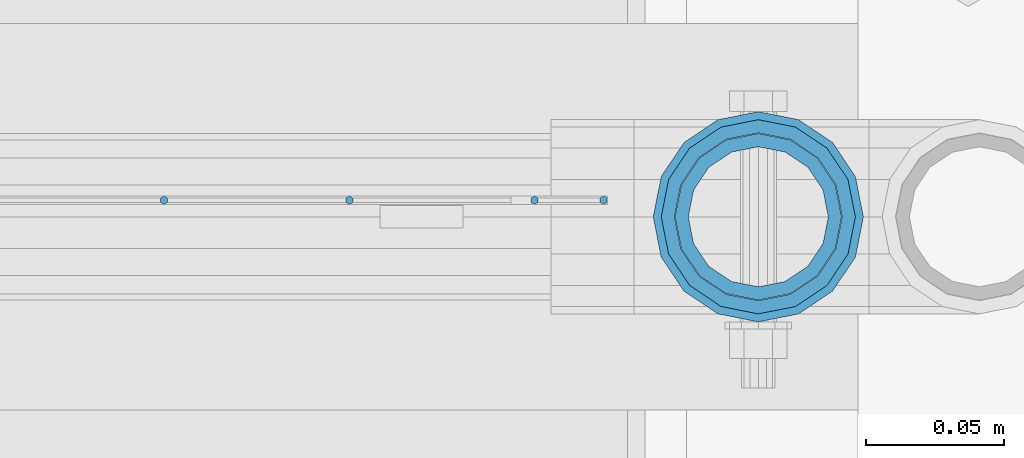
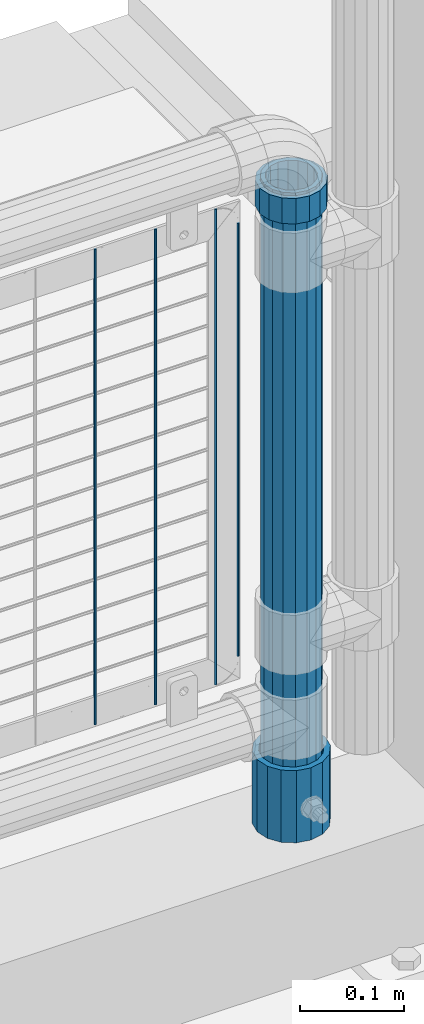
# One storey, part 88 of 208: 7 columns.
"""IFC2X3 building model written with IfcOpenShell, lengths in millimetres."""

import ifcopenshell
import ifcopenshell.guid

model = None  # the IFC model being written
_history = None  # IfcOwnerHistory: only IFC2X3 demands one
_inside = {}  # id of a spatial element -> (the spatial element, [elements in it])
_under = {}  # id of a project, library or spatial element -> (it, [spatial elements below it])
_declared = {}  # id of a project -> (the project, [libraries it declares])
_typed = {}  # id of a type object -> (the type object, [elements of that type])
_made_of = {}  # id of a material, layer set ... -> (it, [elements and type objects made of it])


def new_model(schema):
    """Start an empty IFC model of exactly this schema.

    Asked for "IFC4X3", IfcOpenShell would pick the latest addendum, in which some entities
    have other attributes; the version numbers below select the first issue.
    IFC2X3 requires an IfcOwnerHistory on every rooted entity: one is made here for all.
    """
    global model, _history
    if schema == "IFC4X3":
        model = ifcopenshell.file(schema_version=(4, 3, 0, 0))
    else:
        model = ifcopenshell.file(schema=schema)
    _inside.clear()
    _under.clear()
    _declared.clear()
    _typed.clear()
    _made_of.clear()
    _history = None
    if model.schema == "IFC2X3":
        org = make("IfcOrganization", Name="unknown")
        user = make(
            "IfcPersonAndOrganization",
            ThePerson=make("IfcPerson", FamilyName="unknown"),
            TheOrganization=org,
        )
        app = make(
            "IfcApplication",
            ApplicationDeveloper=org,
            Version="unknown",
            ApplicationFullName="unknown",
            ApplicationIdentifier="unknown",
        )
        _history = make(
            "IfcOwnerHistory",
            OwningUser=user,
            OwningApplication=app,
            ChangeAction="ADDED",
            CreationDate=0,
        )
    return model


def make(cls, **values):
    """One entity of the class cls with the attributes given. An attribute that is None is left unset."""
    return model.create_entity(
        cls, **{name: value for name, value in values.items() if value is not None}
    )


def rooted(cls, **values):
    """An entity with a GlobalId (a new one), such as an element, a storey or a relation."""
    return make(cls, GlobalId=ifcopenshell.guid.new(), OwnerHistory=_history, **values)


def si_unit(unit_type, name, prefix=None):
    """IfcSIUnit, for example si_unit("LENGTHUNIT", "METRE", prefix="MILLI")."""
    return make("IfcSIUnit", UnitType=unit_type, Prefix=prefix, Name=name)


def assignment(units):
    """IfcUnitAssignment: the units of a project."""
    return None if units is None else make("IfcUnitAssignment", Units=units)


def point(xyz):
    """IfcCartesianPoint."""
    return None if xyz is None else make("IfcCartesianPoint", Coordinates=xyz)


def direction(xyz):
    """IfcDirection."""
    return None if xyz is None else make("IfcDirection", DirectionRatios=xyz)


def frame(location, z_axis=None, x_axis=None):
    """IfcAxis2Placement3D, a coordinate frame: its origin and axes. An axis left out is left unset."""
    return make(
        "IfcAxis2Placement3D",
        Location=point(location),
        Axis=direction(z_axis),
        RefDirection=direction(x_axis),
    )


def origin_with_axes():
    """The frame at (0, 0, 0) with the z axis (0, 0, 1) and the x axis (1, 0, 0) written out."""
    return frame((0.0, 0.0, 0.0), z_axis=(0.0, 0.0, 1.0), x_axis=(1.0, 0.0, 0.0))


def place(relative_to, where):
    """IfcLocalPlacement: puts the frame where relative to a parent placement (None: the world)."""
    return make(
        "IfcLocalPlacement", PlacementRelTo=relative_to, RelativePlacement=where
    )


def context(
    kind, dimensions, precision=None, world=None, true_north=None, identifier=None
):
    """IfcGeometricRepresentationContext, for example the 3D "Model" context."""
    return make(
        "IfcGeometricRepresentationContext",
        ContextIdentifier=identifier,
        ContextType=kind,
        CoordinateSpaceDimension=dimensions,
        Precision=precision,
        WorldCoordinateSystem=world,
        TrueNorth=true_north,
    )


def subcontext(parent, identifier, kind, view, scale=None):
    """IfcGeometricRepresentationSubContext, for example "Body" below "Model"."""
    return make(
        "IfcGeometricRepresentationSubContext",
        ContextIdentifier=identifier,
        ContextType=kind,
        ParentContext=parent,
        TargetScale=scale,
        TargetView=view,
    )


def project(units=None, contexts=None):
    """IfcProject with its units and contexts."""
    return rooted(
        "IfcProject",
        Name="project",
        RepresentationContexts=contexts,
        UnitsInContext=assignment(units),
    )


def spatial(cls, under=None, at=None, **own):
    """A site, building, storey or space (cls), placed at a placement, below another one or the project."""
    s = rooted(cls, ObjectPlacement=at, **own)
    if under is not None:
        _under.setdefault(under.id(), (under, []))[1].append(s)
    return s


def faces_of(points, faces, orient=None, outer=None):
    """IfcFace entities. A face is a list of loops; a loop is a list of indices into points, from 0.

    orient and outer hold one flag for each loop. By default every Orientation is true, the
    first loop of a face is its IfcFaceOuterBound and the others are IfcFaceBound.
    """
    made = []
    for i, loops in enumerate(faces):
        bounds = []
        for j, loop in enumerate(loops):
            is_outer = j == 0 if outer is None else outer[i][j]
            bounds.append(
                make(
                    "IfcFaceOuterBound" if is_outer else "IfcFaceBound",
                    Bound=make("IfcPolyLoop", Polygon=[points[k] for k in loop]),
                    Orientation=True if orient is None else orient[i][j],
                )
            )
        made.append(make("IfcFace", Bounds=bounds))
    return made


def faceted_brep(points, faces, orient=None, outer=None, voids=None):
    """IfcFacetedBrep: a solid bounded by flat faces; with voids (closed shells), ...WithVoids."""
    shared = [point(p) for p in points]
    hull = make("IfcClosedShell", CfsFaces=faces_of(shared, faces, orient, outer))
    if voids is None:
        return make("IfcFacetedBrep", Outer=hull)
    return make(
        "IfcFacetedBrepWithVoids",
        Outer=hull,
        Voids=[
            make(cls, CfsFaces=faces_of(shared, fs, o, b)) for cls, fs, o, b in voids
        ],
    )


def shape(context_of_items, identifier, shape_type, items):
    """IfcShapeRepresentation: the items that make up one representation, for example the "Body"."""
    return make(
        "IfcShapeRepresentation",
        ContextOfItems=context_of_items,
        RepresentationIdentifier=identifier,
        RepresentationType=shape_type,
        Items=items,
    )


def material(Name=None, Category=None):
    """IfcMaterial."""
    return make("IfcMaterial", Name=Name, Category=Category)


def made_of(thing, what):
    """Note that an element or type object is made of a material, layer set ...; save() writes the relation."""
    if what is not None:
        _made_of.setdefault(what.id(), (what, []))[1].append(thing)
    return thing


def type_object(cls, material=None, **own):
    """A type object (cls), such as IfcWallType, which elements share."""
    return made_of(rooted(cls, **own), material)


def element(
    cls,
    number,
    at=None,
    inside=None,
    cuts=None,
    type_object=None,
    material=None,
    context=None,
    identifier="Body",
    shape_type=None,
    held_by="IfcProductDefinitionShape",
    body=None,
    shapes=None,
    **own,
):
    """One element of the class cls, such as IfcWall. Its Tag is "e" and its number.

    at: its placement. inside: the storey or other place that contains it. cuts: it is an
    opening in that element (IfcRelVoidsElement). A single representation is given by context,
    identifier, shape_type and body (its items); several are given by shapes. held_by: the class
    of the entity that holds the representations. save() writes the other relations.
    """
    e = rooted(cls, Tag="e%d" % number, ObjectPlacement=at, **own)
    if body is not None:
        shapes = [shape(context, identifier, shape_type, body)]
    if shapes is not None:
        e.Representation = make(held_by, Representations=shapes)
    if inside is not None:
        _inside.setdefault(inside.id(), (inside, []))[1].append(e)
    if cuts is not None:
        rooted(
            "IfcRelVoidsElement", RelatingBuildingElement=cuts, RelatedOpeningElement=e
        )
    if type_object is not None:
        _typed.setdefault(type_object.id(), (type_object, []))[1].append(e)
    return made_of(e, material)


def aggregate(whole, parts):
    """IfcRelAggregates: a whole, such as a stair, and the parts it consists of."""
    return rooted("IfcRelAggregates", RelatingObject=whole, RelatedObjects=parts)


def save(model, path):
    """Write the relations noted so far, then the file.

    IfcRelAggregates (storeys below a building ...), IfcRelContainedInSpatialStructure (elements
    in a storey), IfcRelDefinesByType, IfcRelAssociatesMaterial and IfcRelDeclares: one each for
    every whole, place, type object, material and project.
    """
    for whole, parts in _under.values():
        aggregate(whole, parts)
    for where, things in _inside.values():
        rooted(
            "IfcRelContainedInSpatialStructure",
            RelatedElements=things,
            RelatingStructure=where,
        )
    for kind, things in _typed.values():
        rooted("IfcRelDefinesByType", RelatedObjects=things, RelatingType=kind)
    for what, things in _made_of.values():
        rooted("IfcRelAssociatesMaterial", RelatedObjects=things, RelatingMaterial=what)
    for by, libraries in _declared.values():
        rooted("IfcRelDeclares", RelatingContext=by, RelatedDefinitions=libraries)
    model.write(path)


model = new_model("IFC2X3")

# Units and contexts
model_context = context("Model", 3, precision=1e-05, world=origin_with_axes())
body_context = subcontext(model_context, "Body", "Model", "MODEL_VIEW")
ifc_project = project(units=[si_unit("LENGTHUNIT", "METRE", prefix="MILLI"), si_unit("AREAUNIT", "SQUARE_METRE"), si_unit("VOLUMEUNIT", "CUBIC_METRE"), si_unit("MASSUNIT", "GRAM", prefix="KILO"), si_unit("TIMEUNIT", "SECOND"), si_unit("PLANEANGLEUNIT", "RADIAN"), si_unit("SOLIDANGLEUNIT", "STERADIAN"), si_unit("THERMODYNAMICTEMPERATUREUNIT", "DEGREE_CELSIUS"), si_unit("LUMINOUSINTENSITYUNIT", "LUMEN")], contexts=[model_context])

# Site, building, storey
site_placement = place(None, origin_with_axes())
site = spatial("IfcSite", under=ifc_project, at=site_placement, CompositionType="ELEMENT")
building_placement = place(site_placement, origin_with_axes())
building = spatial("IfcBuilding", under=site, at=building_placement, Name="Standard", CompositionType="ELEMENT")
storey_placement = place(building_placement, origin_with_axes())
storey = spatial("IfcBuildingStorey", under=building, at=storey_placement, Name="Undefined", CompositionType="ELEMENT", Elevation=0.0)

# Columns
ifc_material_1 = material()
column_type_1 = type_object("IfcColumnType", PredefinedType="NOTDEFINED")
column_1_placement = place(storey_placement, frame((-26229.0, 4664.5, 168.019999999998), z_axis=(0.0, 1.0, 0.0), x_axis=(0.0, 0.0, 1.0)))
element("IfcColumn", 1, at=column_1_placement, inside=storey, type_object=column_type_1, material=ifc_material_1, context=body_context, shape_type="Brep", body=[
    faceted_brep([(0.0, -31.75, 0.0), (0.0, -29.3331751572332, 12.1501989775916), (85.0, -29.3331751572332, 12.1501989775916), (85.0, -31.75, 0.0), (0.0, -22.4506403026717, 22.4506403026726), (85.0, -22.4506403026717, 22.4506403026726), (0.0, -12.1501989775934, 29.3331751572332), (85.0, -12.1501989775934, 29.3331751572332), (0.0, 0.0, 31.75), (85.0, 0.0, 31.75), (0.0, 12.1501989775934, 29.3331751572332), (85.0, 12.1501989775934, 29.3331751572332), (0.0, 22.4506403026717, 22.4506403026726), (85.0, 22.4506403026717, 22.4506403026726), (0.0, 29.3331751572332, 12.1501989775916), (85.0, 29.3331751572332, 12.1501989775916), (0.0, 31.75, 0.0), (85.0, 31.75, 0.0), (0.0, 29.3331751572332, -12.1501989775916), (85.0, 29.3331751572332, -12.1501989775916), (0.0, 22.4506403026717, -22.4506403026726), (85.0, 22.4506403026717, -22.4506403026726), (0.0, 12.1501989775934, -29.3331751572332), (85.0, 12.1501989775934, -29.3331751572332), (0.0, 0.0, -31.75), (85.0, 0.0, -31.75), (0.0, -12.1501989775934, -29.3331751572332), (85.0, -12.1501989775934, -29.3331751572332), (0.0, -22.4506403026717, -22.4506403026726), (85.0, -22.4506403026717, -22.4506403026726), (0.0, -29.3331751572332, -12.1501989775916), (85.0, -29.3331751572332, -12.1501989775916), (0.0, -38.0499999999993, 0.0), (0.0, -35.1536162120537, -14.5611046014919), (85.0, -35.1536162120537, -14.5611046014919), (85.0, -38.0499999999993, 0.0), (0.0, -26.9054130241493, -26.9054130241484), (85.0, -26.9054130241493, -26.9054130241484), (0.0, -14.5611046014928, -35.1536162120547), (85.0, -14.5611046014928, -35.1536162120547), (0.0, 0.0, -38.0500000000002), (85.0, 0.0, -38.0500000000002), (0.0, 14.5611046014928, -35.1536162120547), (85.0, 14.5611046014928, -35.1536162120547), (0.0, 26.9054130241493, -26.9054130241484), (85.0, 26.9054130241493, -26.9054130241484), (0.0, 35.1536162120537, -14.5611046014919), (85.0, 35.1536162120537, -14.5611046014919), (0.0, 38.0499999999993, 0.0), (85.0, 38.0499999999993, 0.0), (0.0, 35.1536162120537, 14.5611046014919), (85.0, 35.1536162120537, 14.5611046014919), (0.0, 26.9054130241493, 26.9054130241484), (85.0, 26.9054130241493, 26.9054130241484), (0.0, 14.5611046014928, 35.1536162120547), (85.0, 14.5611046014928, 35.1536162120547), (0.0, 0.0, 38.0500000000002), (85.0, 0.0, 38.0500000000002), (0.0, -14.5611046014928, 35.1536162120547), (85.0, -14.5611046014928, 35.1536162120547), (0.0, -26.9054130241493, 26.9054130241484), (85.0, -26.9054130241493, 26.9054130241484), (0.0, -35.1536162120537, 14.5611046014919), (85.0, -35.1536162120537, 14.5611046014919)], [[[0, 1, 2, 3]], [[1, 4, 5, 2]], [[4, 6, 7, 5]], [[6, 8, 9, 7]], [[8, 10, 11, 9]], [[10, 12, 13, 11]], [[12, 14, 15, 13]], [[14, 16, 17, 15]], [[16, 18, 19, 17]], [[18, 20, 21, 19]], [[20, 22, 23, 21]], [[22, 24, 25, 23]], [[24, 26, 27, 25]], [[26, 28, 29, 27]], [[28, 30, 31, 29]], [[30, 0, 3, 31]], [[32, 33, 34, 35]], [[33, 36, 37, 34]], [[36, 38, 39, 37]], [[38, 40, 41, 39]], [[40, 42, 43, 41]], [[42, 44, 45, 43]], [[44, 46, 47, 45]], [[46, 48, 49, 47]], [[48, 50, 51, 49]], [[50, 52, 53, 51]], [[52, 54, 55, 53]], [[54, 56, 57, 55]], [[56, 58, 59, 57]], [[58, 60, 61, 59]], [[60, 62, 63, 61]], [[62, 32, 35, 63]], [[37, 39, 41, 43, 45, 47, 49, 51, 53, 55, 57, 59, 61, 63, 35, 34], [5, 7, 9, 11, 13, 15, 17, 19, 21, 23, 25, 27, 29, 31, 3, 2]], [[62, 60, 58, 56, 54, 52, 50, 48, 46, 44, 42, 40, 38, 36, 33, 32], [30, 28, 26, 24, 22, 20, 18, 16, 14, 12, 10, 8, 6, 4, 1, 0]]]),
])
ifc_material_2 = material(Name="Misc_Undefined")
column_type_2 = type_object("IfcColumnType", PredefinedType="NOTDEFINED")
column_2_placement = place(storey_placement, frame((-26229.0, 4664.5, 894.85), z_axis=(1.0, 0.0, 0.0), x_axis=(0.0, 0.0, 1.0)))
element("IfcColumn", 2, at=column_2_placement, inside=storey, type_object=column_type_2, material=ifc_material_2, context=body_context, shape_type="Brep", body=[
    faceted_brep([(0.0, -30.3500000000004, 0.0), (0.0, -28.0397438117179, 11.6144421722784), (30.0, -28.0397438117179, 11.6144421722805), (30.0, -30.3500000000004, 0.0), (0.0, -21.4606908090118, 21.4606908090136), (30.0, -21.4606908090118, 21.4606908090117), (0.0, -11.6144421722802, 28.0397438117143), (30.0, -11.6144421722802, 28.0397438117175), (0.0, 0.0, 30.3499999999985), (30.0, 0.0, 30.35), (0.0, 11.6144421722802, 28.0397438117143), (30.0, 11.6144421722802, 28.0397438117175), (0.0, 21.4606908090118, 21.4606908090136), (30.0, 21.4606908090118, 21.4606908090117), (0.0, 28.0397438117179, 11.6144421722784), (30.0, 28.0397438117179, 11.6144421722805), (0.0, 30.3500000000004, 0.0), (30.0, 30.3500000000004, 0.0), (0.0, 28.0397438117179, -11.6144421722784), (30.0, 28.0397438117179, -11.6144421722805), (0.0, 21.4606908090118, -21.4606908090136), (30.0, 21.4606908090118, -21.4606908090117), (0.0, 11.6144421722802, -28.0397438117143), (30.0, 11.6144421722802, -28.0397438117175), (0.0, 0.0, -30.3499999999985), (30.0, 0.0, -30.35), (0.0, -11.6144421722802, -28.0397438117143), (30.0, -11.6144421722802, -28.0397438117175), (0.0, -21.4606908090118, -21.4606908090136), (30.0, -21.4606908090118, -21.4606908090117), (0.0, -28.0397438117179, -11.6144421722784), (30.0, -28.0397438117179, -11.6144421722805), (0.0, -35.1499999999996, 0.0), (0.0, -32.4743655677721, -13.4513226476338), (30.0, -32.4743655677721, -13.4513226476329), (30.0, -35.1499999999996, 0.0), (0.0, -24.8548033587067, -24.8548033587067), (30.0, -24.8548033587067, -24.8548033587072), (0.0, -13.4513226476329, -32.4743655677739), (30.0, -13.4513226476329, -32.4743655677717), (0.0, 0.0, -35.1499999999996), (30.0, 0.0, -35.15), (0.0, 13.4513226476329, -32.4743655677739), (30.0, 13.4513226476329, -32.4743655677717), (0.0, 24.8548033587067, -24.8548033587067), (30.0, 24.8548033587067, -24.8548033587072), (0.0, 32.4743655677721, -13.4513226476338), (30.0, 32.4743655677721, -13.4513226476329), (0.0, 35.1499999999996, 0.0), (30.0, 35.1499999999996, 0.0), (0.0, 32.4743655677721, 13.4513226476338), (30.0, 32.4743655677721, 13.4513226476329), (0.0, 24.8548033587067, 24.8548033587067), (30.0, 24.8548033587067, 24.8548033587072), (0.0, 13.4513226476329, 32.4743655677739), (30.0, 13.4513226476329, 32.4743655677717), (0.0, 0.0, 35.1499999999996), (30.0, 0.0, 35.15), (0.0, -13.4513226476329, 32.4743655677739), (30.0, -13.4513226476329, 32.4743655677717), (0.0, -24.8548033587067, 24.8548033587067), (30.0, -24.8548033587067, 24.8548033587072), (0.0, -32.4743655677721, 13.4513226476338), (30.0, -32.4743655677721, 13.4513226476329)], [[[0, 1, 2, 3]], [[1, 4, 5, 2]], [[4, 6, 7, 5]], [[6, 8, 9, 7]], [[8, 10, 11, 9]], [[10, 12, 13, 11]], [[12, 14, 15, 13]], [[14, 16, 17, 15]], [[16, 18, 19, 17]], [[18, 20, 21, 19]], [[20, 22, 23, 21]], [[22, 24, 25, 23]], [[24, 26, 27, 25]], [[26, 28, 29, 27]], [[28, 30, 31, 29]], [[30, 0, 3, 31]], [[32, 33, 34, 35]], [[33, 36, 37, 34]], [[36, 38, 39, 37]], [[38, 40, 41, 39]], [[40, 42, 43, 41]], [[42, 44, 45, 43]], [[44, 46, 47, 45]], [[46, 48, 49, 47]], [[48, 50, 51, 49]], [[50, 52, 53, 51]], [[52, 54, 55, 53]], [[54, 56, 57, 55]], [[56, 58, 59, 57]], [[58, 60, 61, 59]], [[60, 62, 63, 61]], [[62, 32, 35, 63]], [[37, 39, 41, 43, 45, 47, 49, 51, 53, 55, 57, 59, 61, 63, 35, 34], [5, 7, 9, 11, 13, 15, 17, 19, 21, 23, 25, 27, 29, 31, 3, 2]], [[62, 60, 58, 56, 54, 52, 50, 48, 46, 44, 42, 40, 38, 36, 33, 32], [30, 28, 26, 24, 22, 20, 18, 16, 14, 12, 10, 8, 6, 4, 1, 0]]]),
])
column_type_3 = type_object("IfcColumnType", PredefinedType="NOTDEFINED")
column_3_placement = place(storey_placement, frame((-26229.0, 4664.5, 168.019999999998), z_axis=(-1.0, 0.0, 0.0), x_axis=(0.0, 0.0, 1.0)))
element("IfcColumn", 3, at=column_3_placement, inside=storey, type_object=column_type_3, material=ifc_material_1, context=body_context, shape_type="Brep", body=[
    faceted_brep([(0.0, -25.3500000000004, 0.0), (0.0, -23.4203461491616, 9.70102501045403), (760.0, -23.4203461491616, 9.70102501045403), (760.0, -25.3500000000004, 0.0), (0.0, -17.9251569030794, 17.9251569030785), (760.0, -17.9251569030794, 17.9251569030785), (0.0, -9.70102501045494, 23.4203461491597), (760.0, -9.70102501045494, 23.4203461491597), (0.0, 0.0, 25.3499999999985), (760.0, 0.0, 25.3499999999985), (0.0, 9.70102501045494, 23.4203461491597), (760.0, 9.70102501045494, 23.4203461491597), (0.0, 17.9251569030794, 17.9251569030785), (760.0, 17.9251569030794, 17.9251569030785), (0.0, 23.4203461491616, 9.70102501045403), (760.0, 23.4203461491616, 9.70102501045403), (0.0, 25.3500000000004, 0.0), (760.0, 25.3500000000004, 0.0), (0.0, 23.4203461491616, -9.70102501045403), (760.0, 23.4203461491616, -9.70102501045403), (0.0, 17.9251569030794, -17.9251569030785), (760.0, 17.9251569030794, -17.9251569030785), (0.0, 9.70102501045494, -23.4203461491597), (760.0, 9.70102501045494, -23.4203461491597), (0.0, 0.0, -25.3499999999985), (760.0, 0.0, -25.3499999999985), (0.0, -9.70102501045494, -23.4203461491597), (760.0, -9.70102501045494, -23.4203461491597), (0.0, -17.9251569030794, -17.9251569030785), (760.0, -17.9251569030794, -17.9251569030785), (0.0, -23.4203461491616, -9.70102501045403), (760.0, -23.4203461491616, -9.70102501045403), (0.0, -30.1499999999996, 0.0), (0.0, -27.8549679052148, -11.5379054858058), (760.0, -27.8549679052148, -11.5379054858058), (760.0, -30.1499999999996, 0.0), (0.0, -21.3192694527743, -21.3192694527752), (760.0, -21.3192694527743, -21.3192694527752), (0.0, -11.5379054858076, -27.8549679052157), (760.0, -11.5379054858076, -27.8549679052157), (0.0, 0.0, -30.1500000000015), (760.0, 0.0, -30.1500000000015), (0.0, 11.5379054858076, -27.8549679052157), (760.0, 11.5379054858076, -27.8549679052157), (0.0, 21.3192694527743, -21.3192694527752), (760.0, 21.3192694527743, -21.3192694527752), (0.0, 27.8549679052157, -11.5379054858058), (760.0, 27.8549679052157, -11.5379054858058), (0.0, 30.1499999999996, 0.0), (760.0, 30.1499999999996, 0.0), (0.0, 27.8549679052157, 11.5379054858058), (760.0, 27.8549679052157, 11.5379054858058), (0.0, 21.3192694527743, 21.3192694527752), (760.0, 21.3192694527743, 21.3192694527752), (0.0, 11.5379054858076, 27.8549679052157), (760.0, 11.5379054858076, 27.8549679052157), (0.0, 0.0, 30.1500000000015), (760.0, 0.0, 30.1500000000015), (0.0, -11.5379054858076, 27.8549679052157), (760.0, -11.5379054858076, 27.8549679052157), (0.0, -21.3192694527743, 21.3192694527752), (760.0, -21.3192694527743, 21.3192694527752), (0.0, -27.8549679052157, 11.5379054858058), (760.0, -27.8549679052157, 11.5379054858058)], [[[0, 1, 2, 3]], [[1, 4, 5, 2]], [[4, 6, 7, 5]], [[6, 8, 9, 7]], [[8, 10, 11, 9]], [[10, 12, 13, 11]], [[12, 14, 15, 13]], [[14, 16, 17, 15]], [[16, 18, 19, 17]], [[18, 20, 21, 19]], [[20, 22, 23, 21]], [[22, 24, 25, 23]], [[24, 26, 27, 25]], [[26, 28, 29, 27]], [[28, 30, 31, 29]], [[30, 0, 3, 31]], [[32, 33, 34, 35]], [[33, 36, 37, 34]], [[36, 38, 39, 37]], [[38, 40, 41, 39]], [[40, 42, 43, 41]], [[42, 44, 45, 43]], [[44, 46, 47, 45]], [[46, 48, 49, 47]], [[48, 50, 51, 49]], [[50, 52, 53, 51]], [[52, 54, 55, 53]], [[54, 56, 57, 55]], [[56, 58, 59, 57]], [[58, 60, 61, 59]], [[60, 62, 63, 61]], [[62, 32, 35, 63]], [[37, 39, 41, 43, 45, 47, 49, 51, 53, 55, 57, 59, 61, 63, 35, 34], [5, 7, 9, 11, 13, 15, 17, 19, 21, 23, 25, 27, 29, 31, 3, 2]], [[62, 60, 58, 56, 54, 52, 50, 48, 46, 44, 42, 40, 38, 36, 33, 32], [30, 28, 26, 24, 22, 20, 18, 16, 14, 12, 10, 8, 6, 4, 1, 0]]]),
])
column_type_4 = type_object("IfcColumnType", Name="D3", PredefinedType="NOTDEFINED")
for number, where, z_axis, x_axis in (
    (4, (-26309.9979999999, 4670.49978410089, 353.02), (-1.0, 0.0, 0.0), (0.0, 0.0, 1.0)),
    (5, (-26377.0259999999, 4670.49979830971, 353.02), (-1.0, 0.0, 0.0), (0.0, 0.0, 1.0)),
    (6, (-26444.0539999999, 4670.49981251852, 353.02), (-1.0, 0.0, 0.0), (0.0, 0.0, 1.0)),
):
    element("IfcColumn", number, at=place(storey_placement, frame(where, z_axis=z_axis, x_axis=x_axis)), inside=storey, type_object=column_type_4, material=ifc_material_2, ObjectType="D3", context=body_context, shape_type="Brep", body=[
        faceted_brep([(0.0, -1.49999999999909, 3.63797880709171e-12), (-7.27595761418343e-12, -0.749999999999091, -1.29903810567669), (560.0, -0.75, -1.29903810567703), (560.0, -1.5, 0.0), (-3.63797880709171e-12, 0.750000000000909, -1.29903810567669), (560.0, 0.75, -1.29903810567703), (0.0, 1.50000000000182, 3.63797880709171e-12), (560.0, 1.5, 0.0), (-3.63797880709171e-12, 0.750000000000909, 1.29903810567669), (560.0, 0.75, 1.29903810567703), (-7.27595761418343e-12, -0.749999999999091, 1.29903810567669), (560.0, -0.75, 1.29903810567703)], [[[0, 1, 2, 3]], [[1, 4, 5, 2]], [[4, 6, 7, 5]], [[6, 8, 9, 7]], [[8, 10, 11, 9]], [[10, 0, 3, 11]], [[5, 7, 9, 11, 3, 2]], [[10, 8, 6, 4, 1, 0]]]),
    ])
column_4_placement = place(storey_placement, frame((-26284.9999999999, 4670.49977880132, 378.02), z_axis=(-1.0, 0.0, 0.0), x_axis=(0.0, 0.0, 1.0)))
element("IfcColumn", 7, at=column_4_placement, inside=storey, type_object=column_type_4, material=ifc_material_2, ObjectType="D3", context=body_context, shape_type="Brep", body=[
    faceted_brep([(0.0, -1.49999999999909, 3.63797880709171e-12), (-7.27595761418343e-12, -0.749999999999091, -1.29903810567669), (510.0, -0.75, -1.29903810567703), (510.0, -1.5, 0.0), (-3.63797880709171e-12, 0.750000000000909, -1.29903810567669), (510.0, 0.75, -1.29903810567703), (0.0, 1.50000000000182, 3.63797880709171e-12), (510.0, 1.5, 0.0), (-3.63797880709171e-12, 0.750000000000909, 1.29903810567669), (510.0, 0.75, 1.29903810567703), (-7.27595761418343e-12, -0.749999999999091, 1.29903810567669), (510.0, -0.75, 1.29903810567703)], [[[0, 1, 2, 3]], [[1, 4, 5, 2]], [[4, 6, 7, 5]], [[6, 8, 9, 7]], [[8, 10, 11, 9]], [[10, 0, 3, 11]], [[5, 7, 9, 11, 3, 2]], [[10, 8, 6, 4, 1, 0]]]),
])

save(model, "model.ifc")
